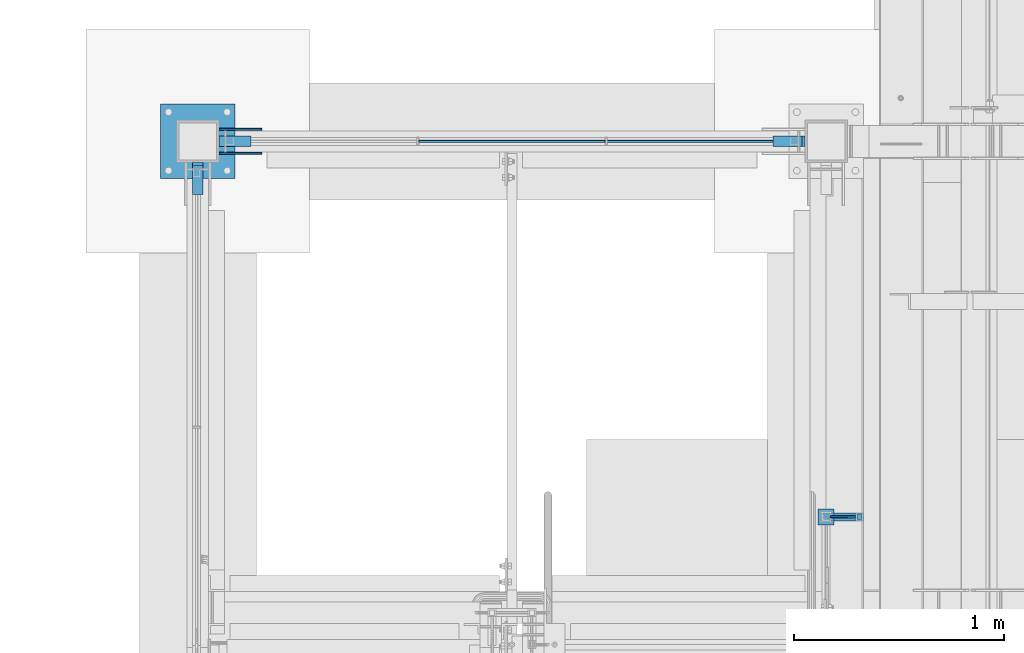
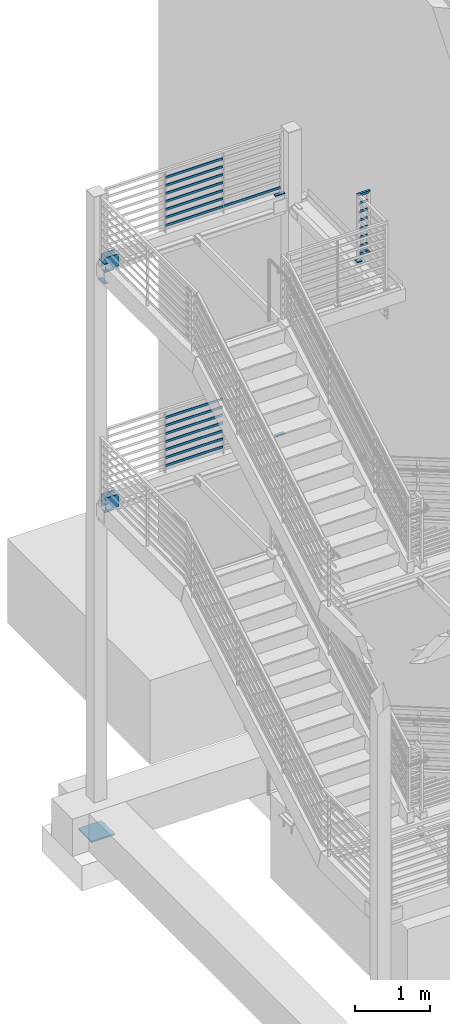
# One storey, part 877 of 1179: 35 beams, 8 elements without a shape of their own.
"""IFC2X3 building model written with IfcOpenShell, lengths in millimetres."""

from ifc_helpers import new_model, si_unit, frame, origin_with_axes, place, context, subcontext, project, spatial, faceted_brep, material, type_object, element, aggregate, save


model = new_model("IFC2X3")

# Units and contexts
model_context = context("Model", 3, precision=1e-05, world=origin_with_axes())
body_context = subcontext(model_context, "Body", "Model", "MODEL_VIEW")
ifc_project = project(units=[si_unit("LENGTHUNIT", "METRE", prefix="MILLI"), si_unit("AREAUNIT", "SQUARE_METRE"), si_unit("VOLUMEUNIT", "CUBIC_METRE"), si_unit("MASSUNIT", "GRAM", prefix="KILO"), si_unit("TIMEUNIT", "SECOND"), si_unit("PLANEANGLEUNIT", "RADIAN"), si_unit("SOLIDANGLEUNIT", "STERADIAN"), si_unit("THERMODYNAMICTEMPERATUREUNIT", "DEGREE_CELSIUS"), si_unit("LUMINOUSINTENSITYUNIT", "LUMEN")], contexts=[model_context])

# Site, building, storey
site_placement = place(None, origin_with_axes())
site = spatial("IfcSite", under=ifc_project, at=site_placement, CompositionType="ELEMENT")
building_placement = place(site_placement, origin_with_axes())
building = spatial("IfcBuilding", under=site, at=building_placement, Name="Undefined", CompositionType="ELEMENT")
storey_placement = place(building_placement, origin_with_axes())
storey = spatial("IfcBuildingStorey", under=building, at=storey_placement, Name="Undefined", CompositionType="ELEMENT", Elevation=0.0)

# Assembly, beam
assembly_1_placement = place(storey_placement, origin_with_axes())
assembly_1 = element("IfcElementAssembly", 1, at=assembly_1_placement, inside=storey, Name="PLATE", AssemblyPlace="NOTDEFINED", PredefinedType="RIGID_FRAME")
ifc_material_1 = material(Name="STEEL/A572-GR.50")
beam_type_1 = type_object("IfcBeamType", PredefinedType="NOTDEFINED")
beam_1_placement = place(assembly_1_placement, frame((-507.999999999998, 37642.8, 8204.2), z_axis=(0.0, 1.0, 0.0), x_axis=(1.0, 0.0, 0.0)))
beam_1 = element("IfcBeam", 2, at=beam_1_placement, type_object=beam_type_1, material=ifc_material_1, Name="PLATE", context=body_context, shape_type="Brep", body=[
    faceted_brep([(152.399999999998, 6.35000000000036, 25.4000000000015), (139.699999999998, -6.35000000000036, 25.4000000000015), (139.699999999998, -6.35000000000036, -25.4000000000015), (152.399999999998, 6.35000000000036, -25.4000000000015), (0.0, -6.35000000000036, -25.4000000000015), (0.0, -6.35000000000036, 25.4000000000015), (0.0, 6.35000000000036, 25.4000000000015), (0.0, 6.35000000000036, -25.4000000000015)], [[[0, 1, 2, 3]], [[4, 5, 6, 7]], [[7, 6, 0, 3]], [[4, 7, 3, 2]], [[5, 4, 2, 1]], [[6, 5, 1, 0]]]),
])
aggregate(assembly_1, [beam_1])

assembly_2_placement = place(storey_placement, origin_with_axes())
assembly_2 = element("IfcElementAssembly", 3, at=assembly_2_placement, inside=storey, Name="PLATE", AssemblyPlace="NOTDEFINED", PredefinedType="RIGID_FRAME")
beam_2_placement = place(assembly_2_placement, frame((-507.999999999998, 37642.8, 4292.6), z_axis=(0.0, 1.0, 0.0), x_axis=(1.0, 0.0, 0.0)))
beam_2 = element("IfcBeam", 4, at=beam_2_placement, type_object=beam_type_1, material=ifc_material_1, Name="PLATE", context=body_context, shape_type="Brep", body=[
    faceted_brep([(152.399999999998, 6.35000000000036, 25.4000000000015), (139.699999999998, -6.35000000000036, 25.4000000000015), (139.699999999998, -6.35000000000036, -25.4000000000015), (152.399999999998, 6.35000000000036, -25.4000000000015), (0.0, -6.35000000000036, -25.4000000000015), (0.0, -6.35000000000036, 25.4000000000015), (0.0, 6.35000000000036, 25.4000000000015), (0.0, 6.35000000000036, -25.4000000000015)], [[[0, 1, 2, 3]], [[4, 5, 6, 7]], [[7, 6, 0, 3]], [[4, 7, 3, 2]], [[5, 4, 2, 1]], [[6, 5, 1, 0]]]),
])
aggregate(assembly_2, [beam_2])

assembly_3_placement = place(storey_placement, origin_with_axes())
assembly_3 = element("IfcElementAssembly", 5, at=assembly_3_placement, inside=storey, Name="COLUMN", AssemblyPlace="NOTDEFINED", PredefinedType="RIGID_FRAME")
beam_3_placement = place(assembly_3_placement, frame((-3251.2, 37388.8, 7886.69999894209), z_axis=(1.0, 0.0, 0.0), x_axis=(0.0, 1.0, 0.0)))
beam_3 = element("IfcBeam", 6, at=beam_3_placement, type_object=beam_type_1, material=ifc_material_1, Name="PLATE", context=body_context, shape_type="Brep", body=[
    faceted_brep([(152.399999999998, 6.35000000000036, 25.4000000000015), (139.699999999998, -6.35000000000036, 25.4000000000015), (139.699999999998, -6.35000000000036, -25.4000000000015), (152.399999999998, 6.35000000000036, -25.4000000000015), (0.0, -6.35000000000036, -25.4000000000015), (0.0, -6.35000000000036, 25.4000000000015), (0.0, 6.35000000000036, 25.4000000000015), (0.0, 6.35000000000036, -25.4000000000015)], [[[0, 1, 2, 3]], [[4, 5, 6, 7]], [[7, 6, 0, 3]], [[4, 7, 3, 2]], [[5, 4, 2, 1]], [[6, 5, 1, 0]]]),
])

assembly_4_placement = place(storey_placement, origin_with_axes())
assembly_4 = element("IfcElementAssembly", 7, at=assembly_4_placement, inside=storey, Name="PLATE", AssemblyPlace="NOTDEFINED", PredefinedType="RIGID_FRAME")
beam_4_placement = place(assembly_4_placement, frame((-3251.2, 37388.8, 8204.19999894209), z_axis=(1.0, 0.0, 0.0), x_axis=(0.0, 1.0, 0.0)))
beam_4 = element("IfcBeam", 8, at=beam_4_placement, type_object=beam_type_1, material=ifc_material_1, Name="PLATE", context=body_context, shape_type="Brep", body=[
    faceted_brep([(152.400000000001, -6.35000000000036, 25.4), (152.400000000001, -6.35000000000036, -25.4), (139.700000000004, 6.35000000000036, -25.4), (139.700000000004, 6.35000000000036, 25.4), (0.0, -6.35000000000036, -25.4000000000015), (0.0, -6.35000000000036, 25.4000000000015), (0.0, 6.35000000000036, 25.4000000000015), (0.0, 6.35000000000036, -25.4000000000015)], [[[0, 1, 2, 3]], [[4, 5, 6, 7]], [[6, 5, 0, 3]], [[7, 6, 3, 2]], [[4, 7, 2, 1]], [[5, 4, 1, 0]]]),
])
aggregate(assembly_4, [beam_4])

# Beam
beam_5_placement = place(assembly_3_placement, frame((-2997.2, 37642.8, 7886.7), z_axis=(0.0, 1.0, 0.0), x_axis=(-1.0, 0.0, 0.0)))
beam_5 = element("IfcBeam", 9, at=beam_5_placement, type_object=beam_type_1, material=ifc_material_1, Name="PLATE", context=body_context, shape_type="Brep", body=[
    faceted_brep([(152.399999999998, 6.35000000000036, 25.4000000000015), (139.699999999998, -6.35000000000036, 25.4000000000015), (139.699999999998, -6.35000000000036, -25.4000000000015), (152.399999999998, 6.35000000000036, -25.4000000000015), (0.0, -6.35000000000036, -25.4000000000015), (0.0, -6.35000000000036, 25.4000000000015), (0.0, 6.35000000000036, 25.4000000000015), (0.0, 6.35000000000036, -25.4000000000015)], [[[0, 1, 2, 3]], [[4, 5, 6, 7]], [[7, 6, 0, 3]], [[4, 7, 3, 2]], [[5, 4, 2, 1]], [[6, 5, 1, 0]]]),
])

beam_6_placement = place(assembly_3_placement, frame((-2997.2, 37642.8, 3975.1), z_axis=(0.0, 1.0, 0.0), x_axis=(-1.0, 0.0, 0.0)))
beam_6 = element("IfcBeam", 10, at=beam_6_placement, type_object=beam_type_1, material=ifc_material_1, Name="PLATE", context=body_context, shape_type="Brep", body=[
    faceted_brep([(152.399999999998, 6.35000000000036, 25.4000000000015), (139.699999999998, -6.35000000000036, 25.4000000000015), (139.699999999998, -6.35000000000036, -25.4000000000015), (152.399999999998, 6.35000000000036, -25.4000000000015), (0.0, -6.35000000000036, -25.4000000000015), (0.0, -6.35000000000036, 25.4000000000015), (0.0, 6.35000000000036, 25.4000000000015), (0.0, 6.35000000000036, -25.4000000000015)], [[[0, 1, 2, 3]], [[4, 5, 6, 7]], [[7, 6, 0, 3]], [[4, 7, 3, 2]], [[5, 4, 2, 1]], [[6, 5, 1, 0]]]),
])

# Assembly, beams
assembly_5_placement = place(storey_placement, origin_with_axes())
assembly_5 = element("IfcElementAssembly", 11, at=assembly_5_placement, inside=storey, Name="GUARDRAIL", AssemblyPlace="NOTDEFINED", PredefinedType="RIGID_FRAME")
ifc_material_2 = material(Name="STEEL/A36")
beam_type_2 = type_object("IfcBeamType", PredefinedType="NOTDEFINED")
beam_7_placement = place(assembly_5_placement, frame((-1303.86666666667, 37642.8, 8305.85291795201), z_axis=(0.0, 0.0, 1.0), x_axis=(1.0, 0.0, 0.0)))
beam_7 = element("IfcBeam", 12, at=beam_7_placement, type_object=beam_type_2, material=ifc_material_2, Name="PLATE", context=body_context, shape_type="Brep", body=[
    faceted_brep([(4.76250000197615, 4.76249999999999, -19.0500000000002), (4.76250000197615, 4.76249999999999, 19.0500000000002), (878.416667431667, 4.76249999999709, 19.0499999999993), (878.416667431667, 4.76249999999709, -19.0499999999993), (4.76250000197615, -4.76249999999999, 19.0500000000002), (878.416667431667, -4.76249999999709, 19.0499999999993), (4.76250000197615, -4.76249999999999, -19.0500000000002), (878.416667431667, -4.76249999999709, -19.0499999999993)], [[[0, 1, 2, 3]], [[1, 4, 5, 2]], [[4, 6, 7, 5]], [[6, 0, 3, 7]], [[5, 7, 3, 2]], [[6, 4, 1, 0]]]),
])
beam_8_placement = place(assembly_5_placement, frame((-2201.33333333333, 37642.8, 8305.85291805541), z_axis=(0.0, 0.0, 1.0), x_axis=(1.0, 0.0, 0.0)))
beam_8 = element("IfcBeam", 13, at=beam_8_placement, type_object=beam_type_2, material=ifc_material_2, Name="PLATE", context=body_context, shape_type="Brep", body=[
    faceted_brep([(4.76250000197615, 4.76249999999999, -19.0500000000002), (4.76250000197615, 4.76249999999999, 19.0500000000002), (892.704166666667, 4.76249999999709, 19.0499999999993), (892.704166666667, 4.76249999999709, -19.0499999999993), (4.76250000197615, -4.76249999999999, 19.0500000000002), (892.704166666667, -4.76249999999709, 19.0499999999993), (4.76250000197615, -4.76249999999999, -19.0500000000002), (892.704166666667, -4.76249999999709, -19.0499999999993)], [[[0, 1, 2, 3]], [[1, 4, 5, 2]], [[4, 6, 7, 5]], [[6, 0, 3, 7]], [[5, 7, 3, 2]], [[6, 4, 1, 0]]]),
])
beam_9_placement = place(assembly_5_placement, frame((-2201.33333333333, 37642.8, 8436.02791850333), z_axis=(0.0, 0.0, 1.0), x_axis=(1.0, 0.0, 0.0)))
beam_9 = element("IfcBeam", 14, at=beam_9_placement, type_object=beam_type_2, material=ifc_material_2, Name="PLATE", context=body_context, shape_type="Brep", body=[
    faceted_brep([(4.76250000197615, 4.76249999999999, -19.0500000000002), (4.76250000197615, 4.76249999999999, 19.0500000000002), (892.704166666667, 4.76249999999709, 19.0499999999993), (892.704166666667, 4.76249999999709, -19.0499999999993), (4.76250000197615, -4.76249999999999, 19.0500000000002), (892.704166666667, -4.76249999999709, 19.0499999999993), (4.76250000197615, -4.76249999999999, -19.0500000000002), (892.704166666667, -4.76249999999709, -19.0499999999993)], [[[0, 1, 2, 3]], [[1, 4, 5, 2]], [[4, 6, 7, 5]], [[6, 0, 3, 7]], [[5, 7, 3, 2]], [[6, 4, 1, 0]]]),
])
beam_10_placement = place(assembly_5_placement, frame((-2201.33333333333, 37642.8, 8566.20291806265), z_axis=(0.0, 0.0, 1.0), x_axis=(1.0, 0.0, 0.0)))
beam_10 = element("IfcBeam", 15, at=beam_10_placement, type_object=beam_type_2, material=ifc_material_2, Name="PLATE", context=body_context, shape_type="Brep", body=[
    faceted_brep([(4.76250000197615, 4.76249999999999, -19.0500000000002), (4.76250000197615, 4.76249999999999, 19.0500000000002), (892.704166666667, 4.76249999999709, 19.0499999999993), (892.704166666667, 4.76249999999709, -19.0499999999993), (4.76250000197615, -4.76249999999999, 19.0500000000002), (892.704166666667, -4.76249999999709, 19.0499999999993), (4.76250000197615, -4.76249999999999, -19.0500000000002), (892.704166666667, -4.76249999999709, -19.0499999999993)], [[[0, 1, 2, 3]], [[1, 4, 5, 2]], [[4, 6, 7, 5]], [[6, 0, 3, 7]], [[5, 7, 3, 2]], [[6, 4, 1, 0]]]),
])
beam_11_placement = place(assembly_5_placement, frame((-2201.33333333333, 37642.8, 8696.37791907579), z_axis=(0.0, 0.0, 1.0), x_axis=(1.0, 0.0, 0.0)))
beam_11 = element("IfcBeam", 16, at=beam_11_placement, type_object=beam_type_2, material=ifc_material_2, Name="PLATE", context=body_context, shape_type="Brep", body=[
    faceted_brep([(4.76250000197615, 4.76249999999999, -19.0500000000002), (4.76250000197615, 4.76249999999999, 19.0500000000002), (892.704166666667, 4.76249999999709, 19.0499999999993), (892.704166666667, 4.76249999999709, -19.0499999999993), (4.76250000197615, -4.76249999999999, 19.0500000000002), (892.704166666667, -4.76249999999709, 19.0499999999993), (4.76250000197615, -4.76249999999999, -19.0500000000002), (892.704166666667, -4.76249999999709, -19.0499999999993)], [[[0, 1, 2, 3]], [[1, 4, 5, 2]], [[4, 6, 7, 5]], [[6, 0, 3, 7]], [[5, 7, 3, 2]], [[6, 4, 1, 0]]]),
])
beam_12_placement = place(assembly_5_placement, frame((-2201.33333333333, 37642.8, 8826.55291907406), z_axis=(0.0, 0.0, 1.0), x_axis=(1.0, 0.0, 0.0)))
beam_12 = element("IfcBeam", 17, at=beam_12_placement, type_object=beam_type_2, material=ifc_material_2, Name="PLATE", context=body_context, shape_type="Brep", body=[
    faceted_brep([(4.76250000197615, 4.76249999999999, -19.0500000000002), (4.76250000197615, 4.76249999999999, 19.0500000000002), (892.704166666667, 4.76249999999709, 19.0499999999993), (892.704166666667, 4.76249999999709, -19.0499999999993), (4.76250000197615, -4.76249999999999, 19.0500000000002), (892.704166666667, -4.76249999999709, 19.0499999999993), (4.76250000197615, -4.76249999999999, -19.0500000000002), (892.704166666667, -4.76249999999709, -19.0499999999993)], [[[0, 1, 2, 3]], [[1, 4, 5, 2]], [[4, 6, 7, 5]], [[6, 0, 3, 7]], [[5, 7, 3, 2]], [[6, 4, 1, 0]]]),
])
beam_13_placement = place(assembly_5_placement, frame((-2201.33333333333, 37642.8, 8956.72791907754), z_axis=(0.0, 0.0, 1.0), x_axis=(1.0, 0.0, 0.0)))
beam_13 = element("IfcBeam", 18, at=beam_13_placement, type_object=beam_type_2, material=ifc_material_2, Name="PLATE", context=body_context, shape_type="Brep", body=[
    faceted_brep([(4.76250000197615, 4.76249999999999, -19.0500000000002), (4.76250000197615, 4.76249999999999, 19.0500000000002), (892.704166666667, 4.76249999999709, 19.0499999999993), (892.704166666667, 4.76249999999709, -19.0499999999993), (4.76250000197615, -4.76249999999999, 19.0500000000002), (892.704166666667, -4.76249999999709, 19.0499999999993), (4.76250000197615, -4.76249999999999, -19.0500000000002), (892.704166666667, -4.76249999999709, -19.0499999999993)], [[[0, 1, 2, 3]], [[1, 4, 5, 2]], [[4, 6, 7, 5]], [[6, 0, 3, 7]], [[5, 7, 3, 2]], [[6, 4, 1, 0]]]),
])
beam_14_placement = place(assembly_5_placement, frame((-2201.33333333333, 37642.8, 9086.90291908278), z_axis=(0.0, 0.0, 1.0), x_axis=(1.0, 0.0, 0.0)))
beam_14 = element("IfcBeam", 19, at=beam_14_placement, type_object=beam_type_2, material=ifc_material_2, Name="PLATE", context=body_context, shape_type="Brep", body=[
    faceted_brep([(4.76250000197615, 4.76249999999999, -19.0500000000002), (4.76250000197615, 4.76249999999999, 19.0500000000002), (892.704166666667, 4.76249999999709, 19.0499999999993), (892.704166666667, 4.76249999999709, -19.0499999999993), (4.76250000197615, -4.76249999999999, 19.0500000000002), (892.704166666667, -4.76249999999709, 19.0499999999993), (4.76250000197615, -4.76249999999999, -19.0500000000002), (892.704166666667, -4.76249999999709, -19.0499999999993)], [[[0, 1, 2, 3]], [[1, 4, 5, 2]], [[4, 6, 7, 5]], [[6, 0, 3, 7]], [[5, 7, 3, 2]], [[6, 4, 1, 0]]]),
])
aggregate(assembly_5, [beam_7, beam_8, beam_9, beam_10, beam_11, beam_12, beam_13, beam_14])

assembly_6_placement = place(storey_placement, origin_with_axes())
assembly_6 = element("IfcElementAssembly", 20, at=assembly_6_placement, inside=storey, Name="GUARDRAIL", AssemblyPlace="NOTDEFINED", PredefinedType="RIGID_FRAME")
beam_15_placement = place(assembly_6_placement, frame((-254.007829504567, 35852.100000474, 8375.702920325), z_axis=(0.000410753999850442, 0.0, 0.999999915640572), x_axis=(0.999999915640572, 9.99973457871227e-10, -0.000410753999850448)))
beam_15 = element("IfcBeam", 21, at=beam_15_placement, type_object=beam_type_2, material=ifc_material_2, Name="PLATE", context=body_context, shape_type="Brep", body=[
    faceted_brep([(19.0656505782412, 4.76249999993888, -19.0499999999884), (19.0499992371956, 4.76249999999709, 19.0499999999993), (139.697518572973, 4.76249999956053, 19.0500000001248), (139.714963993092, 4.76249999956053, -19.049999999881), (19.0499992371956, -4.76249999999709, 19.0499999999993), (139.697518563478, -4.76250000044092, 19.0500000001284), (19.0656505687465, -4.7625000000553, -19.0499999999847), (139.714963983598, -4.76250000043365, -19.0499999998774)], [[[0, 1, 2, 3]], [[1, 4, 5, 2]], [[4, 6, 7, 5]], [[6, 0, 3, 7]], [[5, 7, 3, 2]], [[6, 4, 1, 0]]]),
])
beam_16_placement = place(assembly_6_placement, frame((-254.007829504567, 35852.100000607, 8515.34814627325), z_axis=(0.000410753999850442, 0.0, 0.999999915640572), x_axis=(0.999999915640572, 9.99973457871227e-10, -0.000410753999850448)))
beam_16 = element("IfcBeam", 22, at=beam_16_placement, type_object=beam_type_2, material=ifc_material_2, Name="PLATE", context=body_context, shape_type="Brep", body=[
    faceted_brep([(19.0656505782412, 4.76249999993888, -19.0499999999884), (19.0499992371956, 4.76249999999709, 19.0499999999993), (139.690936953206, 4.76249999956053, 19.0500000001266), (139.708382373325, 4.76249999956053, -19.0499999998774), (19.0499992371956, -4.76249999999709, 19.0499999999993), (139.690936943711, -4.76250000044092, 19.0500000001302), (19.0656505687465, -4.7625000000553, -19.0499999999847), (139.708382363831, -4.76250000043365, -19.0499999998738)], [[[0, 1, 2, 3]], [[1, 4, 5, 2]], [[4, 6, 7, 5]], [[6, 0, 3, 7]], [[5, 7, 3, 2]], [[6, 4, 1, 0]]]),
])
beam_17_placement = place(assembly_6_placement, frame((-254.007829504567, 35852.100000607, 8655.04814627325), z_axis=(0.000410753999850442, 0.0, 0.999999915640572), x_axis=(0.999999915640572, 9.99973457871227e-10, -0.000410753999850448)))
beam_17 = element("IfcBeam", 23, at=beam_17_placement, type_object=beam_type_2, material=ifc_material_2, Name="PLATE", context=body_context, shape_type="Brep", body=[
    faceted_brep([(19.0656505782412, 4.76249999993888, -19.0499999999884), (19.0499992371956, 4.76249999999709, 19.0499999999993), (139.684352751883, 4.76249999956053, 19.0500000001248), (139.701798172002, 4.76249999956781, -19.0499999998792), (19.0499992371956, -4.76249999999709, 19.0499999999993), (139.684352742388, -4.76250000044092, 19.0500000001284), (19.0656505687465, -4.7625000000553, -19.0499999999847), (139.701798162508, -4.76250000043365, -19.0499999998756)], [[[0, 1, 2, 3]], [[1, 4, 5, 2]], [[4, 6, 7, 5]], [[6, 0, 3, 7]], [[5, 7, 3, 2]], [[6, 4, 1, 0]]]),
])
beam_18_placement = place(assembly_6_placement, frame((-254.007829504567, 35852.100000607, 8794.74814627324), z_axis=(0.000410753999850442, 0.0, 0.999999915640572), x_axis=(0.999999915640572, 9.99973457871227e-10, -0.000410753999850448)))
beam_18 = element("IfcBeam", 24, at=beam_18_placement, type_object=beam_type_2, material=ifc_material_2, Name="PLATE", context=body_context, shape_type="Brep", body=[
    faceted_brep([(19.0656505782412, 4.76249999993888, -19.0499999999884), (19.0499992371956, 4.76249999999709, 19.0499999999993), (139.67776855056, 4.76249999956053, 19.0500000001248), (139.695213970679, 4.76249999956053, -19.049999999881), (19.0499992371956, -4.76249999999709, 19.0499999999993), (139.677768541065, -4.76250000044092, 19.0500000001284), (19.0656505687465, -4.7625000000553, -19.0499999999847), (139.695213961185, -4.76250000044092, -19.0499999998756)], [[[0, 1, 2, 3]], [[1, 4, 5, 2]], [[4, 6, 7, 5]], [[6, 0, 3, 7]], [[5, 7, 3, 2]], [[6, 4, 1, 0]]]),
])
beam_19_placement = place(assembly_6_placement, frame((-254.007829504567, 35852.100000607, 8934.44814627324), z_axis=(0.000410753999850442, 0.0, 0.999999915640572), x_axis=(0.999999915640572, 9.99973457871227e-10, -0.000410753999850448)))
beam_19 = element("IfcBeam", 25, at=beam_19_placement, type_object=beam_type_2, material=ifc_material_2, Name="PLATE", context=body_context, shape_type="Brep", body=[
    faceted_brep([(19.0656505782412, 4.76249999993888, -19.0499999999884), (19.0499992371956, 4.76249999999709, 19.0499999999993), (139.671184349237, 4.76249999955326, 19.0500000001266), (139.688629769356, 4.76249999956053, -19.0499999998792), (19.0499992371956, -4.76249999999709, 19.0499999999993), (139.671184339742, -4.76250000044092, 19.0500000001302), (19.0656505687465, -4.7625000000553, -19.0499999999847), (139.688629759862, -4.76250000044092, -19.0499999998756)], [[[0, 1, 2, 3]], [[1, 4, 5, 2]], [[4, 6, 7, 5]], [[6, 0, 3, 7]], [[5, 7, 3, 2]], [[6, 4, 1, 0]]]),
])
beam_20_placement = place(assembly_6_placement, frame((-254.007829504567, 35852.100000607, 9074.14814627324), z_axis=(0.000410753999850442, 0.0, 0.999999915640572), x_axis=(0.999999915640572, 9.99973457871227e-10, -0.000410753999850448)))
beam_20 = element("IfcBeam", 26, at=beam_20_placement, type_object=beam_type_2, material=ifc_material_2, Name="PLATE", context=body_context, shape_type="Brep", body=[
    faceted_brep([(19.0656505782412, 4.76249999993888, -19.0499999999884), (19.0499992371956, 4.76249999999709, 19.0499999999993), (139.664600147914, 4.76249999955326, 19.0500000001266), (139.682045568033, 4.76249999955326, -19.049999999881), (19.0499992371956, -4.76249999999709, 19.0499999999993), (139.664600138419, -4.76250000044092, 19.0500000001302), (19.0656505687465, -4.7625000000553, -19.0499999999847), (139.682045558538, -4.7625000004482, -19.0499999998756)], [[[0, 1, 2, 3]], [[1, 4, 5, 2]], [[4, 6, 7, 5]], [[6, 0, 3, 7]], [[5, 7, 3, 2]], [[6, 4, 1, 0]]]),
])

assembly_7_placement = place(storey_placement, origin_with_axes())
assembly_7 = element("IfcElementAssembly", 27, at=assembly_7_placement, inside=storey, Name="GUARDRAIL", AssemblyPlace="NOTDEFINED", PredefinedType="RIGID_FRAME")
beam_21_placement = place(assembly_7_placement, frame((-2201.33333333333, 37642.8, 4394.25291774519), z_axis=(0.0, 0.0, 1.0), x_axis=(1.0, 0.0, 0.0)))
beam_21 = element("IfcBeam", 28, at=beam_21_placement, type_object=beam_type_2, material=ifc_material_2, Name="PLATE", context=body_context, shape_type="Brep", body=[
    faceted_brep([(4.76250000197615, 4.76249999999999, -19.0500000000002), (4.76250000197615, 4.76249999999999, 19.0500000000002), (892.704166666667, 4.76249999999709, 19.0499999999993), (892.704166666667, 4.76249999999709, -19.0499999999993), (4.76250000197615, -4.76249999999999, 19.0500000000002), (892.704166666667, -4.76249999999709, 19.0499999999993), (4.76250000197615, -4.76249999999999, -19.0500000000002), (892.704166666667, -4.76249999999709, -19.0499999999993)], [[[0, 1, 2, 3]], [[1, 4, 5, 2]], [[4, 6, 7, 5]], [[6, 0, 3, 7]], [[5, 7, 3, 2]], [[6, 4, 1, 0]]]),
])
beam_22_placement = place(assembly_7_placement, frame((-2201.33333333333, 37642.8, 4524.42791819311), z_axis=(0.0, 0.0, 1.0), x_axis=(1.0, 0.0, 0.0)))
beam_22 = element("IfcBeam", 29, at=beam_22_placement, type_object=beam_type_2, material=ifc_material_2, Name="PLATE", context=body_context, shape_type="Brep", body=[
    faceted_brep([(4.76250000197615, 4.76249999999999, -19.0500000000002), (4.76250000197615, 4.76249999999999, 19.0500000000002), (892.704166666667, 4.76249999999709, 19.0499999999993), (892.704166666667, 4.76249999999709, -19.0499999999993), (4.76250000197615, -4.76249999999999, 19.0500000000002), (892.704166666667, -4.76249999999709, 19.0499999999993), (4.76250000197615, -4.76249999999999, -19.0500000000002), (892.704166666667, -4.76249999999709, -19.0499999999993)], [[[0, 1, 2, 3]], [[1, 4, 5, 2]], [[4, 6, 7, 5]], [[6, 0, 3, 7]], [[5, 7, 3, 2]], [[6, 4, 1, 0]]]),
])
beam_23_placement = place(assembly_7_placement, frame((-2201.33333333333, 37642.8, 4654.60291775242), z_axis=(0.0, 0.0, 1.0), x_axis=(1.0, 0.0, 0.0)))
beam_23 = element("IfcBeam", 30, at=beam_23_placement, type_object=beam_type_2, material=ifc_material_2, Name="PLATE", context=body_context, shape_type="Brep", body=[
    faceted_brep([(4.76250000197615, 4.76249999999999, -19.0500000000002), (4.76250000197615, 4.76249999999999, 19.0500000000002), (892.704166666667, 4.76249999999709, 19.0499999999993), (892.704166666667, 4.76249999999709, -19.0499999999993), (4.76250000197615, -4.76249999999999, 19.0500000000002), (892.704166666667, -4.76249999999709, 19.0499999999993), (4.76250000197615, -4.76249999999999, -19.0500000000002), (892.704166666667, -4.76249999999709, -19.0499999999993)], [[[0, 1, 2, 3]], [[1, 4, 5, 2]], [[4, 6, 7, 5]], [[6, 0, 3, 7]], [[5, 7, 3, 2]], [[6, 4, 1, 0]]]),
])
beam_24_placement = place(assembly_7_placement, frame((-2201.33333333333, 37642.8, 4784.77791876556), z_axis=(0.0, 0.0, 1.0), x_axis=(1.0, 0.0, 0.0)))
beam_24 = element("IfcBeam", 31, at=beam_24_placement, type_object=beam_type_2, material=ifc_material_2, Name="PLATE", context=body_context, shape_type="Brep", body=[
    faceted_brep([(4.76250000197615, 4.76249999999999, -19.0500000000002), (4.76250000197615, 4.76249999999999, 19.0500000000002), (892.704166666667, 4.76249999999709, 19.0499999999993), (892.704166666667, 4.76249999999709, -19.0499999999993), (4.76250000197615, -4.76249999999999, 19.0500000000002), (892.704166666667, -4.76249999999709, 19.0499999999993), (4.76250000197615, -4.76249999999999, -19.0500000000002), (892.704166666667, -4.76249999999709, -19.0499999999993)], [[[0, 1, 2, 3]], [[1, 4, 5, 2]], [[4, 6, 7, 5]], [[6, 0, 3, 7]], [[5, 7, 3, 2]], [[6, 4, 1, 0]]]),
])
beam_25_placement = place(assembly_7_placement, frame((-2201.33333333333, 37642.8, 4914.95291876383), z_axis=(0.0, 0.0, 1.0), x_axis=(1.0, 0.0, 0.0)))
beam_25 = element("IfcBeam", 32, at=beam_25_placement, type_object=beam_type_2, material=ifc_material_2, Name="PLATE", context=body_context, shape_type="Brep", body=[
    faceted_brep([(4.76250000197615, 4.76249999999999, -19.0500000000002), (4.76250000197615, 4.76249999999999, 19.0500000000002), (892.704166666667, 4.76249999999709, 19.0499999999993), (892.704166666667, 4.76249999999709, -19.0499999999993), (4.76250000197615, -4.76249999999999, 19.0500000000002), (892.704166666667, -4.76249999999709, 19.0499999999993), (4.76250000197615, -4.76249999999999, -19.0500000000002), (892.704166666667, -4.76249999999709, -19.0499999999993)], [[[0, 1, 2, 3]], [[1, 4, 5, 2]], [[4, 6, 7, 5]], [[6, 0, 3, 7]], [[5, 7, 3, 2]], [[6, 4, 1, 0]]]),
])
beam_26_placement = place(assembly_7_placement, frame((-2201.33333333333, 37642.8, 5045.12791876732), z_axis=(0.0, 0.0, 1.0), x_axis=(1.0, 0.0, 0.0)))
beam_26 = element("IfcBeam", 33, at=beam_26_placement, type_object=beam_type_2, material=ifc_material_2, Name="PLATE", context=body_context, shape_type="Brep", body=[
    faceted_brep([(4.76250000197615, 4.76249999999999, -19.0500000000002), (4.76250000197615, 4.76249999999999, 19.0500000000002), (892.704166666667, 4.76249999999709, 19.0499999999993), (892.704166666667, 4.76249999999709, -19.0499999999993), (4.76250000197615, -4.76249999999999, 19.0500000000002), (892.704166666667, -4.76249999999709, 19.0499999999993), (4.76250000197615, -4.76249999999999, -19.0500000000002), (892.704166666667, -4.76249999999709, -19.0499999999993)], [[[0, 1, 2, 3]], [[1, 4, 5, 2]], [[4, 6, 7, 5]], [[6, 0, 3, 7]], [[5, 7, 3, 2]], [[6, 4, 1, 0]]]),
])
beam_27_placement = place(assembly_7_placement, frame((-2201.33333333333, 37642.8, 5175.30291877255), z_axis=(0.0, 0.0, 1.0), x_axis=(1.0, 0.0, 0.0)))
beam_27 = element("IfcBeam", 34, at=beam_27_placement, type_object=beam_type_2, material=ifc_material_2, Name="PLATE", context=body_context, shape_type="Brep", body=[
    faceted_brep([(4.76250000197615, 4.76249999999999, -19.0500000000002), (4.76250000197615, 4.76249999999999, 19.0500000000002), (892.704166666667, 4.76249999999709, 19.0499999999993), (892.704166666667, 4.76249999999709, -19.0499999999993), (4.76250000197615, -4.76249999999999, 19.0500000000002), (892.704166666667, -4.76249999999709, 19.0499999999993), (4.76250000197615, -4.76249999999999, -19.0500000000002), (892.704166666667, -4.76249999999709, -19.0499999999993)], [[[0, 1, 2, 3]], [[1, 4, 5, 2]], [[4, 6, 7, 5]], [[6, 0, 3, 7]], [[5, 7, 3, 2]], [[6, 4, 1, 0]]]),
])
aggregate(assembly_7, [beam_21, beam_22, beam_23, beam_24, beam_25, beam_26, beam_27])

# Beam
ifc_material_3 = material()
beam_type_3 = type_object("IfcBeamType", Name="HSS1-1/2X1-1/2X1/4", PredefinedType="NOTDEFINED")
beam_28_placement = place(assembly_6_placement, frame((-254.000004638121, 35852.100000607, 8254.99814466621), z_axis=(0.000410753999850442, 0.0, 0.999999915640572), x_axis=(0.999999915640572, 9.99973457871227e-10, -0.000410753999850448)))
beam_28 = element("IfcBeam", 35, at=beam_28_placement, type_object=beam_type_3, material=ifc_material_3, Name="GUARDRAIL", ObjectType="HSS1-1/2X1-1/2X1/4", context=body_context, shape_type="Brep", body=[
    faceted_brep([(19.0552174306587, 12.6999993299323, -12.6999993299905), (19.0552174053395, -12.6999993300706, -12.6999993299814), (171.459922420804, -12.6999993305435, -12.6999993298414), (171.459922420713, 12.6999993294521, -12.6999993298523), (19.0447842534367, -12.6999993300633, 12.6999993300233), (146.048290772111, -12.6999993304635, 12.6999993301379), (19.0447842787558, 12.6999993299323, 12.6999993300124), (146.04829077202, 12.6999993295394, 12.6999993301288), (19.0578257250628, 19.049999234936, -19.0499992349942), (19.0421759970114, 19.049999234936, 19.0499992350124), (139.695382619714, 19.0499992345503, 19.0499992351215), (177.812830572973, 19.0499992344339, -19.0499992348505), (19.0421759590326, -19.0499992350669, 19.0499992350287), (139.69538261985, -19.0499992354526, 19.0499992351361), (19.057825687084, -19.0499992350669, -19.0499992349778), (177.81283057311, -19.0499992355617, -19.0499992348359)], [[[0, 1, 2, 3]], [[1, 4, 5, 2]], [[4, 6, 7, 5]], [[6, 0, 3, 7]], [[8, 9, 10, 11]], [[9, 12, 13, 10]], [[12, 14, 15, 13]], [[14, 8, 11, 15]], [[13, 15, 11, 10], [5, 7, 3, 2]], [[14, 12, 9, 8], [6, 4, 1, 0]]]),
])

beam_29_placement = place(assembly_6_placement, frame((-254.000004638329, 35852.100000784, 9213.78554587396), z_axis=(-0.000410751999858149, 0.0, 0.999999915641394), x_axis=(0.999999915641394, -9.99973457926778e-10, 0.000410751999858147)))
beam_29 = element("IfcBeam", 36, at=beam_29_placement, type_object=beam_type_3, material=ifc_material_3, Name="GUARDRAIL", ObjectType="HSS1-1/2X1-1/2X1/4", context=body_context, shape_type="Brep", body=[
    faceted_brep([(-12.7037965197983, 12.6999993299542, -12.6999993299942), (12.7066330913057, -12.6999993299687, -12.6999993299833), (146.004293632223, -12.6999993295467, -12.6999993299796), (146.004293632314, 12.6999993304562, -12.6999993299905), (12.7066331167064, -12.6999993299614, 12.6999993299996), (171.413529987429, -12.6999993294594, 12.6999993300033), (-12.7037964943975, 12.6999993299614, 12.6999993299887), (171.41352998752, 12.6999993305435, 12.6999993299924), (-19.056404169023, 19.049999234936, -19.0499992349924), (-19.0564041309219, 19.049999234936, 19.0499992349796), (177.765839316431, 19.0499992355617, 19.0499992349869), (139.651984303449, 19.049999235438, -19.0499992349905), (19.0592407659311, -19.0499992349432, 19.0499992349978), (177.765839316294, -19.0499992344412, 19.0499992350015), (19.05924072783, -19.0499992349432, -19.049999234976), (139.651984303312, -19.0499992345576, -19.0499992349742)], [[[0, 1, 2, 3]], [[1, 4, 5, 2]], [[4, 6, 7, 5]], [[6, 0, 3, 7]], [[8, 9, 10, 11]], [[9, 12, 13, 10]], [[12, 14, 15, 13]], [[14, 8, 11, 15]], [[13, 15, 11, 10], [5, 7, 3, 2]], [[14, 12, 9, 8], [6, 4, 1, 0]]]),
])

aggregate(assembly_6, [beam_28, beam_15, beam_16, beam_17, beam_18, beam_19, beam_20, beam_29])

# Assembly, beam
assembly_8_placement = place(storey_placement, origin_with_axes())
assembly_8 = element("IfcElementAssembly", 37, at=assembly_8_placement, inside=storey, Name="SLEEVE", AssemblyPlace="NOTDEFINED", PredefinedType="RIGID_FRAME")
beam_type_4 = type_object("IfcBeamType", PredefinedType="NOTDEFINED")
beam_30_placement = place(assembly_8_placement, frame((-292.100004638119, 35852.100000607, 8140.75477407027), z_axis=(0.0, 1.0, 0.0), x_axis=(1.0, 0.0, 0.0)))
beam_30 = element("IfcBeam", 38, at=beam_30_placement, type_object=beam_type_4, material=ifc_material_2, Name="PLATE", context=body_context, shape_type="Brep", body=[
    faceted_brep([(0.0, 6.35000000000036, -38.0999999999985), (0.0, 6.35000000000036, 38.0999999999985), (76.2, 6.35000000000036, 38.0999999999985), (76.2, 6.35000000000036, -38.0999999999985), (0.0, -6.35000000000036, 38.0999999999985), (76.2, -6.35000000000036, 38.0999999999985), (0.0, -6.35000000000036, -38.0999999999985), (76.2, -6.35000000000036, -38.0999999999985)], [[[0, 1, 2, 3]], [[1, 4, 5, 2]], [[4, 6, 7, 5]], [[6, 0, 3, 7]], [[5, 7, 3, 2]], [[6, 4, 1, 0]]]),
])
aggregate(assembly_8, [beam_30])

# Beam
beam_type_5 = type_object("IfcBeamType", PredefinedType="NOTDEFINED")
beam_31_placement = place(assembly_3_placement, frame((-2946.4, 37699.95, 8045.45), z_axis=(0.0, 0.0, 1.0), x_axis=(-1.0, 0.0, 0.0)))
beam_31 = element("IfcBeam", 39, at=beam_31_placement, type_object=beam_type_5, material=ifc_material_2, Name="PLATE", context=body_context, shape_type="Brep", body=[
    faceted_brep([(0.0, 4.76250000000073, -101.6), (0.0, 4.76250000000073, 101.6), (203.199999999997, 4.76250000000073, 101.6), (203.199999999997, 4.76250000000073, -101.6), (0.0, -4.76250000000073, 101.6), (203.199999999997, -4.76250000000073, 101.6), (0.0, -4.76250000000073, -101.6), (203.199999999997, -4.76250000000073, -101.6)], [[[0, 1, 2, 3]], [[1, 4, 5, 2]], [[4, 6, 7, 5]], [[6, 0, 3, 7]], [[5, 7, 3, 2]], [[6, 4, 1, 0]]]),
])

beam_32_placement = place(assembly_3_placement, frame((-2946.4, 37585.65, 8045.45), z_axis=(0.0, 0.0, 1.0), x_axis=(-1.0, 0.0, 0.0)))
beam_32 = element("IfcBeam", 40, at=beam_32_placement, type_object=beam_type_5, material=ifc_material_2, Name="PLATE", context=body_context, shape_type="Brep", body=[
    faceted_brep([(0.0, 4.76250000000073, -101.6), (0.0, 4.76250000000073, 101.6), (203.199999999997, 4.76250000000073, 101.6), (203.199999999997, 4.76250000000073, -101.6), (0.0, -4.76250000000073, 101.6), (203.199999999997, -4.76250000000073, 101.6), (0.0, -4.76250000000073, -101.6), (203.199999999997, -4.76250000000073, -101.6)], [[[0, 1, 2, 3]], [[1, 4, 5, 2]], [[4, 6, 7, 5]], [[6, 0, 3, 7]], [[5, 7, 3, 2]], [[6, 4, 1, 0]]]),
])

beam_33_placement = place(assembly_3_placement, frame((-2946.4, 37699.95, 4133.85), z_axis=(0.0, 0.0, 1.0), x_axis=(-1.0, 0.0, 0.0)))
beam_33 = element("IfcBeam", 41, at=beam_33_placement, type_object=beam_type_5, material=ifc_material_2, Name="PLATE", context=body_context, shape_type="Brep", body=[
    faceted_brep([(0.0, 4.76250000000073, -101.6), (0.0, 4.76250000000073, 101.6), (203.199999999997, 4.76250000000073, 101.6), (203.199999999997, 4.76250000000073, -101.6), (0.0, -4.76250000000073, 101.6), (203.199999999997, -4.76250000000073, 101.6), (0.0, -4.76250000000073, -101.6), (203.199999999997, -4.76250000000073, -101.6)], [[[0, 1, 2, 3]], [[1, 4, 5, 2]], [[4, 6, 7, 5]], [[6, 0, 3, 7]], [[5, 7, 3, 2]], [[6, 4, 1, 0]]]),
])

beam_34_placement = place(assembly_3_placement, frame((-2946.4, 37585.65, 4133.85), z_axis=(0.0, 0.0, 1.0), x_axis=(-1.0, 0.0, 0.0)))
beam_34 = element("IfcBeam", 42, at=beam_34_placement, type_object=beam_type_5, material=ifc_material_2, Name="PLATE", context=body_context, shape_type="Brep", body=[
    faceted_brep([(0.0, 4.76250000000073, -101.6), (0.0, 4.76250000000073, 101.6), (203.199999999997, 4.76250000000073, 101.6), (203.199999999997, 4.76250000000073, -101.6), (0.0, -4.76250000000073, 101.6), (203.199999999997, -4.76250000000073, 101.6), (0.0, -4.76250000000073, -101.6), (203.199999999997, -4.76250000000073, -101.6)], [[[0, 1, 2, 3]], [[1, 4, 5, 2]], [[4, 6, 7, 5]], [[6, 0, 3, 7]], [[5, 7, 3, 2]], [[6, 4, 1, 0]]]),
])

beam_type_6 = type_object("IfcBeamType", PredefinedType="NOTDEFINED")
beam_35_placement = place(assembly_3_placement, frame((-3251.2, 37465.0000030518, -1193.8), z_axis=(-1.0, 0.0, 0.0), x_axis=(0.0, 1.0, 0.0)))
beam_35 = element("IfcBeam", 43, at=beam_35_placement, type_object=beam_type_6, material=ifc_material_1, context=body_context, shape_type="Brep", body=[
    faceted_brep([(0.0, 12.7, -177.8), (9.50323374127038e-06, 12.7000000000007, 177.80000656152), (355.599999999999, 12.7, 177.8), (355.599999999999, 12.7, -177.8), (9.50323374127038e-06, -12.7000000000007, 177.80000656152), (355.599999999999, -12.7, 177.8), (0.0, -12.7, -177.8), (355.599999999999, -12.7, -177.8)], [[[0, 1, 2, 3]], [[1, 4, 5, 2]], [[4, 6, 7, 5]], [[6, 0, 3, 7]], [[5, 7, 3, 2]], [[6, 4, 1, 0]]]),
])

aggregate(assembly_3, [beam_3, beam_31, beam_32, beam_5, beam_33, beam_34, beam_6, beam_35])

save(model, "model.ifc")
